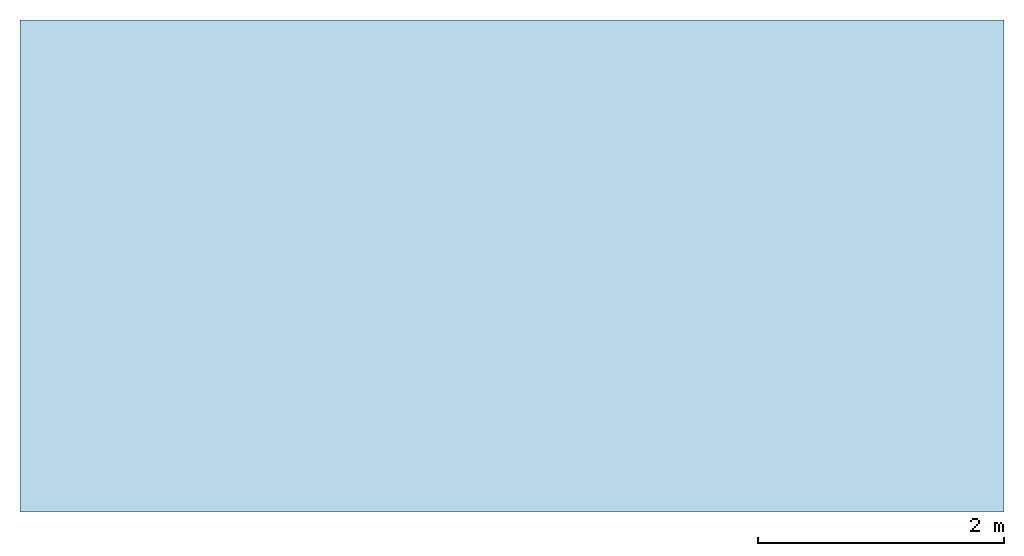
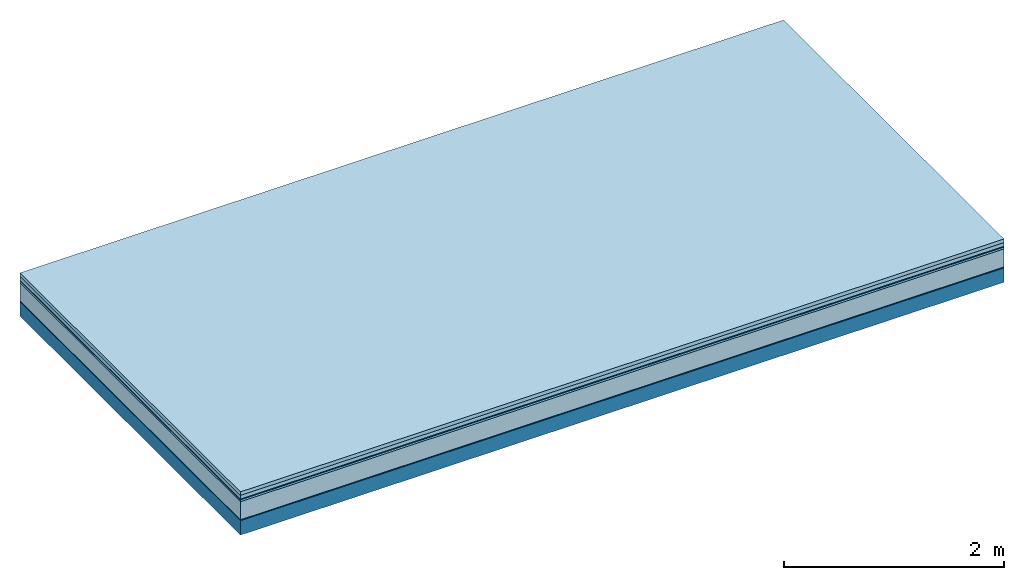
# One storey: 6 plates, 1 member, 1 element without a shape of its own.
"""IFC4 building model written with IfcOpenShell, lengths in metres."""

import ifcopenshell
import ifcopenshell.guid

model = None  # the IFC model being written
_history = None  # IfcOwnerHistory: only IFC2X3 demands one
_inside = {}  # id of a spatial element -> (the spatial element, [elements in it])
_under = {}  # id of a project, library or spatial element -> (it, [spatial elements below it])
_declared = {}  # id of a project -> (the project, [libraries it declares])
_typed = {}  # id of a type object -> (the type object, [elements of that type])
_made_of = {}  # id of a material, layer set ... -> (it, [elements and type objects made of it])


def new_model(schema):
    """Start an empty IFC model of exactly this schema.

    Asked for "IFC4X3", IfcOpenShell would pick the latest addendum, in which some entities
    have other attributes; the version numbers below select the first issue.
    IFC2X3 requires an IfcOwnerHistory on every rooted entity: one is made here for all.
    """
    global model, _history
    if schema == "IFC4X3":
        model = ifcopenshell.file(schema_version=(4, 3, 0, 0))
    else:
        model = ifcopenshell.file(schema=schema)
    _inside.clear()
    _under.clear()
    _declared.clear()
    _typed.clear()
    _made_of.clear()
    _history = None
    if model.schema == "IFC2X3":
        org = make("IfcOrganization", Name="unknown")
        user = make(
            "IfcPersonAndOrganization",
            ThePerson=make("IfcPerson", FamilyName="unknown"),
            TheOrganization=org,
        )
        app = make(
            "IfcApplication",
            ApplicationDeveloper=org,
            Version="unknown",
            ApplicationFullName="unknown",
            ApplicationIdentifier="unknown",
        )
        _history = make(
            "IfcOwnerHistory",
            OwningUser=user,
            OwningApplication=app,
            ChangeAction="ADDED",
            CreationDate=0,
        )
    return model


def make(cls, **values):
    """One entity of the class cls with the attributes given. An attribute that is None is left unset."""
    return model.create_entity(
        cls, **{name: value for name, value in values.items() if value is not None}
    )


def rooted(cls, **values):
    """An entity with a GlobalId (a new one), such as an element, a storey or a relation."""
    return make(cls, GlobalId=ifcopenshell.guid.new(), OwnerHistory=_history, **values)


def si_unit(unit_type, name, prefix=None):
    """IfcSIUnit, for example si_unit("LENGTHUNIT", "METRE", prefix="MILLI")."""
    return make("IfcSIUnit", UnitType=unit_type, Prefix=prefix, Name=name)


def derived_unit(unit_type, elements):
    """IfcDerivedUnit: a product of units, each with its exponent."""
    return make(
        "IfcDerivedUnit",
        Elements=[
            make("IfcDerivedUnitElement", Unit=unit, Exponent=power)
            for unit, power in elements
        ],
        UnitType=unit_type,
    )


def assignment(units):
    """IfcUnitAssignment: the units of a project."""
    return None if units is None else make("IfcUnitAssignment", Units=units)


def point(xyz):
    """IfcCartesianPoint."""
    return None if xyz is None else make("IfcCartesianPoint", Coordinates=xyz)


def direction(xyz):
    """IfcDirection."""
    return None if xyz is None else make("IfcDirection", DirectionRatios=xyz)


def frame(location, z_axis=None, x_axis=None):
    """IfcAxis2Placement3D, a coordinate frame: its origin and axes. An axis left out is left unset."""
    return make(
        "IfcAxis2Placement3D",
        Location=point(location),
        Axis=direction(z_axis),
        RefDirection=direction(x_axis),
    )


def frame_2d(location, x_axis=None):
    """IfcAxis2Placement2D, a coordinate frame in the plane: its origin and x axis."""
    return make(
        "IfcAxis2Placement2D", Location=point(location), RefDirection=direction(x_axis)
    )


def origin():
    """The frame at (0, 0, 0) with its axes left unset."""
    return frame((0.0, 0.0, 0.0))


def origin_with_axes():
    """The frame at (0, 0, 0) with the z axis (0, 0, 1) and the x axis (1, 0, 0) written out."""
    return frame((0.0, 0.0, 0.0), z_axis=(0.0, 0.0, 1.0), x_axis=(1.0, 0.0, 0.0))


def place(relative_to, where):
    """IfcLocalPlacement: puts the frame where relative to a parent placement (None: the world)."""
    return make(
        "IfcLocalPlacement", PlacementRelTo=relative_to, RelativePlacement=where
    )


def context(
    kind, dimensions, precision=None, world=None, true_north=None, identifier=None
):
    """IfcGeometricRepresentationContext, for example the 3D "Model" context."""
    return make(
        "IfcGeometricRepresentationContext",
        ContextIdentifier=identifier,
        ContextType=kind,
        CoordinateSpaceDimension=dimensions,
        Precision=precision,
        WorldCoordinateSystem=world,
        TrueNorth=true_north,
    )


def project(units=None, contexts=None):
    """IfcProject with its units and contexts."""
    return rooted(
        "IfcProject",
        Name="project",
        RepresentationContexts=contexts,
        UnitsInContext=assignment(units),
    )


def spatial(cls, under=None, at=None, **own):
    """A site, building, storey or space (cls), placed at a placement, below another one or the project."""
    s = rooted(cls, ObjectPlacement=at, **own)
    if under is not None:
        _under.setdefault(under.id(), (under, []))[1].append(s)
    return s


def profile(cls, at=None, kind="AREA", **sizes):
    """A parametric profile (cls). Its sizes go by their IFC names, for example OverallWidth=200.0."""
    return make(cls, ProfileType=kind, Position=at, **sizes)


def rectangle(**sizes):
    """IfcRectangleProfileDef."""
    return profile("IfcRectangleProfileDef", **sizes)


def extrude(swept, where, along, depth):
    """IfcExtrudedAreaSolid: the profile swept, set in the frame where, extruded along a direction by depth."""
    return make(
        "IfcExtrudedAreaSolid",
        SweptArea=swept,
        Position=where,
        ExtrudedDirection=direction(along),
        Depth=depth,
    )


def shape(context_of_items, identifier, shape_type, items):
    """IfcShapeRepresentation: the items that make up one representation, for example the "Body"."""
    return make(
        "IfcShapeRepresentation",
        ContextOfItems=context_of_items,
        RepresentationIdentifier=identifier,
        RepresentationType=shape_type,
        Items=items,
    )


def material(Name=None, Category=None):
    """IfcMaterial."""
    return make("IfcMaterial", Name=Name, Category=Category)


def layer(
    of_material, thickness, ventilated=None, Name=None, Category=None, Priority=None
):
    """IfcMaterialLayer: one layer of a wall or slab, of a material (None: an air gap)."""
    return make(
        "IfcMaterialLayer",
        Material=of_material,
        LayerThickness=thickness,
        IsVentilated=ventilated,
        Name=Name,
        Category=Category,
        Priority=Priority,
    )


def layer_set(layers, Name=None):
    """IfcMaterialLayerSet."""
    return make("IfcMaterialLayerSet", MaterialLayers=layers, LayerSetName=Name)


def made_of(thing, what):
    """Note that an element or type object is made of a material, layer set ...; save() writes the relation."""
    if what is not None:
        _made_of.setdefault(what.id(), (what, []))[1].append(thing)
    return thing


def type_object(cls, material=None, **own):
    """A type object (cls), such as IfcWallType, which elements share."""
    return made_of(rooted(cls, **own), material)


def element(
    cls,
    number,
    at=None,
    inside=None,
    cuts=None,
    type_object=None,
    material=None,
    context=None,
    identifier="Body",
    shape_type=None,
    held_by="IfcProductDefinitionShape",
    body=None,
    shapes=None,
    **own,
):
    """One element of the class cls, such as IfcWall. Its Tag is "e" and its number.

    at: its placement. inside: the storey or other place that contains it. cuts: it is an
    opening in that element (IfcRelVoidsElement). A single representation is given by context,
    identifier, shape_type and body (its items); several are given by shapes. held_by: the class
    of the entity that holds the representations. save() writes the other relations.
    """
    e = rooted(cls, Tag="e%d" % number, ObjectPlacement=at, **own)
    if body is not None:
        shapes = [shape(context, identifier, shape_type, body)]
    if shapes is not None:
        e.Representation = make(held_by, Representations=shapes)
    if inside is not None:
        _inside.setdefault(inside.id(), (inside, []))[1].append(e)
    if cuts is not None:
        rooted(
            "IfcRelVoidsElement", RelatingBuildingElement=cuts, RelatedOpeningElement=e
        )
    if type_object is not None:
        _typed.setdefault(type_object.id(), (type_object, []))[1].append(e)
    return made_of(e, material)


def aggregate(whole, parts):
    """IfcRelAggregates: a whole, such as a stair, and the parts it consists of."""
    return rooted("IfcRelAggregates", RelatingObject=whole, RelatedObjects=parts)


def save(model, path):
    """Write the relations noted so far, then the file.

    IfcRelAggregates (storeys below a building ...), IfcRelContainedInSpatialStructure (elements
    in a storey), IfcRelDefinesByType, IfcRelAssociatesMaterial and IfcRelDeclares: one each for
    every whole, place, type object, material and project.
    """
    for whole, parts in _under.values():
        aggregate(whole, parts)
    for where, things in _inside.values():
        rooted(
            "IfcRelContainedInSpatialStructure",
            RelatedElements=things,
            RelatingStructure=where,
        )
    for kind, things in _typed.values():
        rooted("IfcRelDefinesByType", RelatedObjects=things, RelatingType=kind)
    for what, things in _made_of.values():
        rooted("IfcRelAssociatesMaterial", RelatedObjects=things, RelatingMaterial=what)
    for by, libraries in _declared.values():
        rooted("IfcRelDeclares", RelatingContext=by, RelatedDefinitions=libraries)
    model.write(path)


model = new_model("IFC4")

# Units and contexts
plan_context = context("Plan", 3, precision=1e-05, world=origin(), true_north=direction((0.0, 1.0)))
model_context = context("Model", 3, precision=1e-05, world=origin(), true_north=direction((0.0, 1.0)))
ifc_project = project(units=[si_unit("LENGTHUNIT", "METRE"), derived_unit("SOUNDPRESSUREUNIT", [(si_unit("PRESSUREUNIT", "PASCAL", prefix="MICRO"), 0)]), si_unit("ENERGYUNIT", "JOULE", prefix="MEGA"), si_unit("MASSUNIT", "GRAM", prefix="KILO"), derived_unit("THERMALTRANSMITTANCEUNIT", [(si_unit("POWERUNIT", "WATT"), 1), (si_unit("AREAUNIT", "SQUARE_METRE"), -1), (si_unit("THERMODYNAMICTEMPERATUREUNIT", "KELVIN"), -1)]), derived_unit("AREADENSITYUNIT", [(si_unit("MASSUNIT", "GRAM", prefix="KILO"), 1), (si_unit("AREAUNIT", "SQUARE_METRE"), -1)]), derived_unit("USERDEFINED", [(si_unit("ENERGYUNIT", "JOULE", prefix="MEGA"), 1), (si_unit("AREAUNIT", "SQUARE_METRE"), -1)])], contexts=[plan_context, model_context])

# Site, building, storey
site = spatial("IfcSite", under=ifc_project)
building_placement = place(None, origin())
building = spatial("IfcBuilding", under=site, at=building_placement)
storey_placement = place(building_placement, origin())
storey = spatial("IfcBuildingStorey", under=building, at=storey_placement)

# Slab, member, plates
ifc_material_1 = material(Name="Garden plates", Category="02.007")
ifc_layer_1 = layer(ifc_material_1, 0.04, Name="Use and protection layer 3")
ifc_material_2 = material(Name="Gravel 8-16mm", Category="03.011")
ifc_layer_2 = layer(ifc_material_2, 0.04, Name="Use and protection layer 2")
ifc_material_3 = material(Name="Protective layer", Category="09.007")
ifc_layer_3 = layer(ifc_material_3, 0.01, Name="Use and protection layer 1")
ifc_material_4 = material(Name="Bituminous", Category="09.003")
ifc_layer_4 = layer(ifc_material_4, 0.02, Name="Seal")
ifc_material_5 = material(Name="Mineral wool", Category="10.008")
ifc_layer_5 = layer(ifc_material_5, 0.2, Name="Exterior insulation layer 1")
ifc_material_6 = material(Name="Vapor-permeable barrier", Category="09.006")
ifc_layer_6 = layer(ifc_material_6, 0.01, Name="layer / temporary roof")
ifc_material_7 = material(Name="no composite action")
ifc_layer_7 = layer(ifc_material_7, 0.0, Name="Bond")
ifc_layer_8 = layer(None, 0.16, Name="Support")
ifc_layer_set = layer_set([ifc_layer_1, ifc_layer_2, ifc_layer_3, ifc_layer_4, ifc_layer_5, ifc_layer_6, ifc_layer_7, ifc_layer_8])
slab_type = type_object("IfcSlabType", Name="F0049", PredefinedType="NOTDEFINED", material=ifc_layer_set)
slab_placement = place(None, frame((0.0, 0.0, 0.0), z_axis=(0.0, 0.0, -1.0), x_axis=(1.0, 0.0, 0.0)))
slab = element("IfcSlab", 1, at=slab_placement, inside=storey, type_object=slab_type, material=ifc_layer_set, Name="Slab #1")
ifc_material_8 = material(Name="Solid timber panel")
member_placement = place(slab_placement, origin())
member = element("IfcMember", 2, at=member_placement, material=ifc_material_8, Name="Support", context=plan_context, shape_type="SweptSolid", body=[
    extrude(rectangle(XDim=1.0, YDim=0.16, at=frame_2d((0.5, 0.08), x_axis=(1.0, 0.0))), frame((0.0, 4.0, 0.32), z_axis=(0.0, -1.0, 0.0), x_axis=(1.0, 0.0, 0.0)), (0.0, 0.0, 1.0), 4.0),
    extrude(rectangle(XDim=1.0, YDim=0.16, at=frame_2d((0.5, 0.08), x_axis=(1.0, 0.0))), frame((1.0, 4.0, 0.32), z_axis=(0.0, -1.0, 0.0), x_axis=(1.0, 0.0, 0.0)), (0.0, 0.0, 1.0), 4.0),
    extrude(rectangle(XDim=1.0, YDim=0.16, at=frame_2d((0.5, 0.08), x_axis=(1.0, 0.0))), frame((2.0, 4.0, 0.32), z_axis=(0.0, -1.0, 0.0), x_axis=(1.0, 0.0, 0.0)), (0.0, 0.0, 1.0), 4.0),
    extrude(rectangle(XDim=1.0, YDim=0.16, at=frame_2d((0.5, 0.08), x_axis=(1.0, 0.0))), frame((3.0, 4.0, 0.32), z_axis=(0.0, -1.0, 0.0), x_axis=(1.0, 0.0, 0.0)), (0.0, 0.0, 1.0), 4.0),
    extrude(rectangle(XDim=1.0, YDim=0.16, at=frame_2d((0.5, 0.08), x_axis=(1.0, 0.0))), frame((4.0, 4.0, 0.32), z_axis=(0.0, -1.0, 0.0), x_axis=(1.0, 0.0, 0.0)), (0.0, 0.0, 1.0), 4.0),
    extrude(rectangle(XDim=1.0, YDim=0.16, at=frame_2d((0.5, 0.08), x_axis=(1.0, 0.0))), frame((5.0, 4.0, 0.32), z_axis=(0.0, -1.0, 0.0), x_axis=(1.0, 0.0, 0.0)), (0.0, 0.0, 1.0), 4.0),
    extrude(rectangle(XDim=1.0, YDim=0.16, at=frame_2d((0.5, 0.08), x_axis=(1.0, 0.0))), frame((6.0, 4.0, 0.32), z_axis=(0.0, -1.0, 0.0), x_axis=(1.0, 0.0, 0.0)), (0.0, 0.0, 1.0), 4.0),
    extrude(rectangle(XDim=1.0, YDim=0.16, at=frame_2d((0.5, 0.08), x_axis=(1.0, 0.0))), frame((7.0, 4.0, 0.32), z_axis=(0.0, -1.0, 0.0), x_axis=(1.0, 0.0, 0.0)), (0.0, 0.0, 1.0), 4.0),
])
plate_1_placement = place(slab_placement, origin())
plate_1 = element("IfcPlate", 3, at=plate_1_placement, material=ifc_material_1, Name="Use and protection layer 3", context=plan_context, shape_type="SweptSolid", body=[
    extrude(rectangle(XDim=8.0, YDim=4.0, at=frame_2d((4.0, 2.0), x_axis=(1.0, 0.0))), origin_with_axes(), (0.0, 0.0, 1.0), 0.04),
])
plate_2_placement = place(slab_placement, origin())
plate_2 = element("IfcPlate", 4, at=plate_2_placement, material=ifc_material_2, Name="Use and protection layer 2", context=plan_context, shape_type="SweptSolid", body=[
    extrude(rectangle(XDim=8.0, YDim=4.0, at=frame_2d((4.0, 2.0), x_axis=(1.0, 0.0))), frame((0.0, 0.0, 0.04), z_axis=(0.0, 0.0, 1.0), x_axis=(1.0, 0.0, 0.0)), (0.0, 0.0, 1.0), 0.04),
])
plate_3_placement = place(slab_placement, origin())
plate_3 = element("IfcPlate", 5, at=plate_3_placement, material=ifc_material_3, Name="Use and protection layer 1", context=plan_context, shape_type="SweptSolid", body=[
    extrude(rectangle(XDim=8.0, YDim=4.0, at=frame_2d((4.0, 2.0), x_axis=(1.0, 0.0))), frame((0.0, 0.0, 0.08), z_axis=(0.0, 0.0, 1.0), x_axis=(1.0, 0.0, 0.0)), (0.0, 0.0, 1.0), 0.01),
])
plate_4_placement = place(slab_placement, origin())
plate_4 = element("IfcPlate", 6, at=plate_4_placement, material=ifc_material_4, Name="Seal", context=plan_context, shape_type="SweptSolid", body=[
    extrude(rectangle(XDim=8.0, YDim=4.0, at=frame_2d((4.0, 2.0), x_axis=(1.0, 0.0))), frame((0.0, 0.0, 0.09), z_axis=(0.0, 0.0, 1.0), x_axis=(1.0, 0.0, 0.0)), (0.0, 0.0, 1.0), 0.02),
])
plate_5_placement = place(slab_placement, origin())
plate_5 = element("IfcPlate", 7, at=plate_5_placement, material=ifc_material_5, Name="Exterior insulation layer 1", context=plan_context, shape_type="SweptSolid", body=[
    extrude(rectangle(XDim=8.0, YDim=4.0, at=frame_2d((4.0, 2.0), x_axis=(1.0, 0.0))), frame((0.0, 0.0, 0.11), z_axis=(0.0, 0.0, 1.0), x_axis=(1.0, 0.0, 0.0)), (0.0, 0.0, 1.0), 0.2),
])
plate_6_placement = place(slab_placement, origin())
plate_6 = element("IfcPlate", 8, at=plate_6_placement, material=ifc_material_6, Name="layer / temporary roof", context=plan_context, shape_type="SweptSolid", body=[
    extrude(rectangle(XDim=8.0, YDim=4.0, at=frame_2d((4.0, 2.0), x_axis=(1.0, 0.0))), frame((0.0, 0.0, 0.31), z_axis=(0.0, 0.0, 1.0), x_axis=(1.0, 0.0, 0.0)), (0.0, 0.0, 1.0), 0.01),
])
aggregate(slab, [plate_1, plate_2, plate_3, plate_4, plate_5, plate_6, member])

save(model, "model.ifc")
